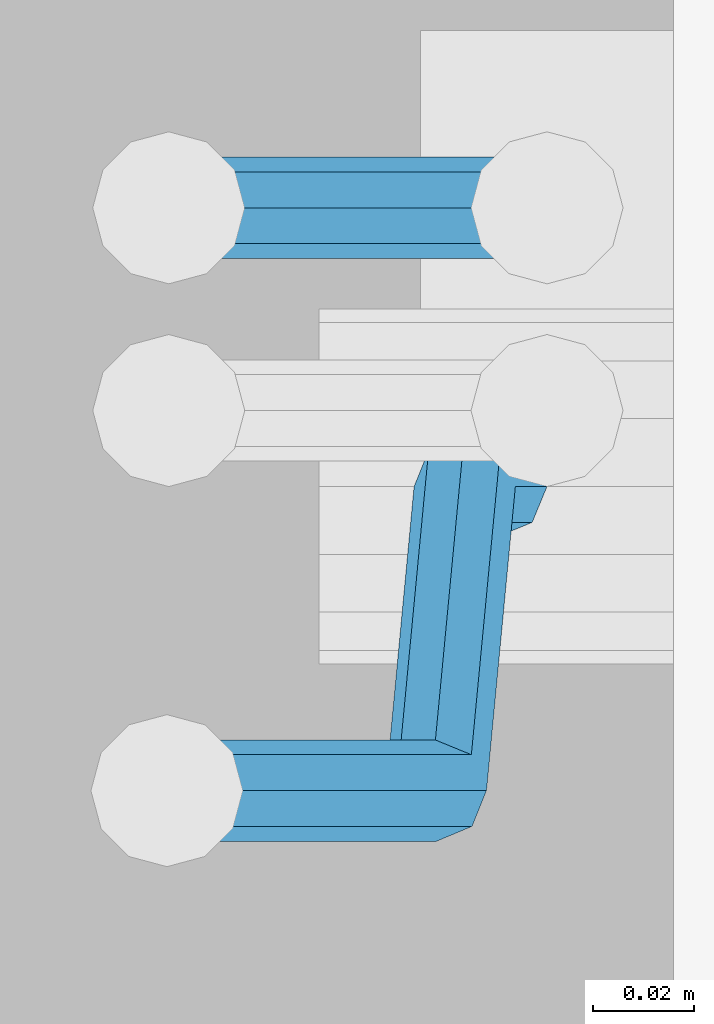
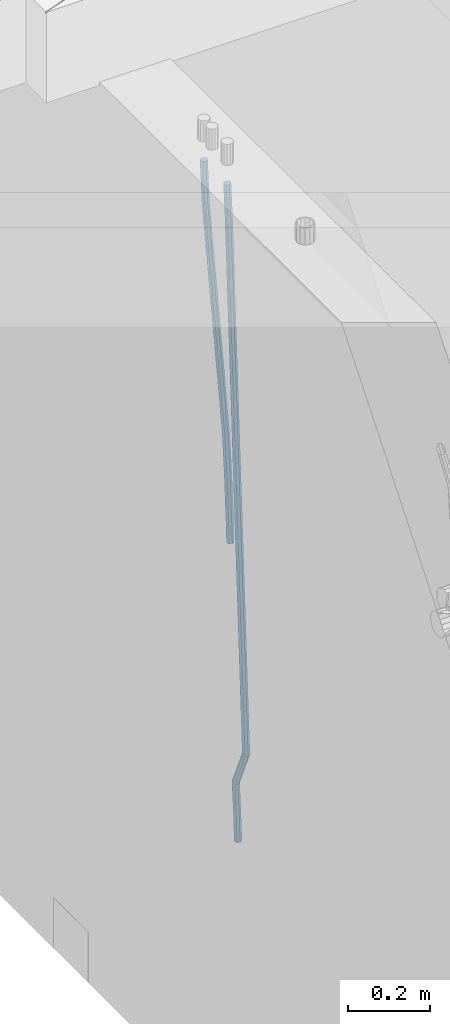
# One storey, part 107 of 350: 2 beams, 1 element without a shape of its own.
"""IFC2X3 building model written with IfcOpenShell, lengths in millimetres."""

from ifc_helpers import new_model, si_unit, frame, origin_with_axes, place, context, subcontext, project, spatial, faceted_brep, material, type_object, element, aggregate, save


model = new_model("IFC2X3")

# Units and contexts
model_context = context("Model", 3, precision=1e-05, world=origin_with_axes())
body_context = subcontext(model_context, "Body", "Model", "MODEL_VIEW")
ifc_project = project(units=[si_unit("LENGTHUNIT", "METRE", prefix="MILLI"), si_unit("AREAUNIT", "SQUARE_METRE"), si_unit("VOLUMEUNIT", "CUBIC_METRE"), si_unit("MASSUNIT", "GRAM", prefix="KILO"), si_unit("TIMEUNIT", "SECOND"), si_unit("PLANEANGLEUNIT", "RADIAN"), si_unit("SOLIDANGLEUNIT", "STERADIAN"), si_unit("THERMODYNAMICTEMPERATUREUNIT", "DEGREE_CELSIUS"), si_unit("LUMINOUSINTENSITYUNIT", "LUMEN")], contexts=[model_context])

# Site, building, storey
site_placement = place(None, origin_with_axes())
site = spatial("IfcSite", under=ifc_project, at=site_placement, CompositionType="ELEMENT")
building_placement = place(site_placement, origin_with_axes())
building = spatial("IfcBuilding", under=site, at=building_placement, CompositionType="ELEMENT")
storey_placement = place(building_placement, origin_with_axes())
storey = spatial("IfcBuildingStorey", under=building, at=storey_placement, Name="2", CompositionType="ELEMENT", Elevation=0.0)

# Assembly, beams
assembly_placement = place(storey_placement, origin_with_axes())
assembly = element("IfcElementAssembly", 1, at=assembly_placement, inside=storey, AssemblyPlace="NOTDEFINED", PredefinedType="REINFORCEMENT_UNIT")
ifc_material = material()
beam_type = type_object("IfcBeamType", Name="D20", PredefinedType="NOTDEFINED")
beam_1_placement = place(assembly_placement, frame((21885.0000022791, 14045.0000000039, 86242.5), z_axis=(-0.999642804636942, -0.000205726999925762, -0.0267249099902983), x_axis=(-0.0267249099948371, 4.30000201934385e-08, 0.999642825806181)))
beam_1 = element("IfcBeam", 2, at=beam_1_placement, type_object=beam_type, material=ifc_material, Name="JM20", ObjectType="D20", context=body_context, shape_type="Brep", body=[
    faceted_brep([(0.0, -10.0, 0.0), (-4.19531716033816e-08, -7.07106781186667, -7.07106781187031), (60.4619050310575, -7.0710677960451, -7.07106780569666), (60.4619050351321, -9.99999998418207, 6.16637407802045e-09), (0.0, 0.0, -10.0), (60.461905027827, 1.58197508426383e-08, -9.99999999383363), (4.196772351861e-08, 7.07106781186303, -7.07106781186667), (60.4619050273614, 7.07106782768642, -7.07106780570393), (0.0, 10.0, 0.0), (60.4619050298934, 10.0000000158198, 6.16273609921336e-09), (4.196772351861e-08, 7.07106781185939, 7.07106781185939), (60.4619050339825, 7.07106782768642, 7.07106781802941), (0.0, 0.0, 10.0), (60.4619050371984, 1.58197508426383e-08, 10.0000000061664), (-4.19531716033816e-08, -7.07106781187031, 7.07106781185939), (60.4619050376641, -7.07106779604692, 7.07106781802941), (61.0129192658205, -7.0710677959014, -7.07106780564573), (60.991799419251, -9.99999998403655, 6.21366780251265e-09), (61.0216667879577, 1.5965269994922e-08, -9.99999999377542), (61.0129104985535, 7.07106782783012, -7.07106780564573), (60.9917724058905, 10.0000000159635, 6.21366780251265e-09), (60.9706525593356, 7.07106782781921, 7.07106781808398), (60.9619050371984, 1.59507180796936e-08, 10.0000000062173), (60.9706613266026, -7.07106779591231, 7.07106781808398), (61.5639236610441, -7.07106711285996, -7.06777487693398), (61.5216697265278, -9.99999932719038, 0.00316667643710389), (61.5814185523195, 7.09851519786753e-07, -9.99665478878524), (61.5639061303518, 7.07106851086064, -7.0677749293136), (61.5216449344152, 10.0000006727951, 0.00316660236785538), (61.4793909998989, 7.07106845846647, 7.07410815574622), (61.4618961086089, 6.35754986433312e-07, 10.0029880675975), (61.4794085305912, -7.07106716525595, 7.07410820811856), (201.449097232471, -7.07089370716676, -6.23178897958132), (201.406843297969, -9.99982592149536, 0.839152573797037), (201.466592123761, 0.000174115546542453, -9.16066889142894), (201.449079701793, 7.07124191655566, -6.23178903195003), (201.406818505828, 10.0001740784883, 0.839152499731426), (201.364564571326, 7.07124186416149, 7.91009405310251), (201.347069680036, 0.000174041450009099, 10.8389739649538), (201.364582102004, -7.07089375956093, 7.91009410547849), (202.064908398519, -7.07089294378966, -6.22810875073264), (201.974688451053, -9.99982521757738, 0.842546146737732), (202.102263221896, 0.000174903541847016, -9.1568699750751), (202.064870972245, 7.07124267990912, -6.22810892200869), (201.974635522289, 10.0001747823735, 0.842545904521103), (201.884415574823, 7.07124250858396, 7.91320080199148), (201.847060751446, 0.000174661254277453, 10.8419620263303), (201.884453001097, -7.07089311511299, 7.91320097326388), (202.680612950673, -7.07089044784516, -6.21607376842803), (202.542435294468, -9.99982291604465, 0.853643714868667), (202.737824267795, 0.000177479978447082, -9.144446864153), (202.680555632222, 7.07124517576995, -6.21607432852397), (202.542354233941, 10.0001770837898, 0.853642922764266), (202.404176577751, 7.07124461559215, 7.92336040606824), (202.3469652606, 0.000176687766725081, 10.8517335017932), (202.404233896188, -7.07089100802477, 7.92336096616782), (324.430210789345, -7.07039689928752, -3.83627285367038), (324.292033133141, -9.99932936748701, 3.23344462962268), (324.487422106482, 0.00067102853608958, -6.76464594940262), (324.430153470879, 7.07173872432759, -3.83627341376996), (324.291952072614, 10.0006706323456, 3.23344383752556), (324.153774416409, 7.07173816414797, 10.3031613208259), (324.096563099272, 0.00067023632254859, 13.2315344165509), (324.15383173486, -7.07039745946895, 10.3031618809218), (325.221961482646, -7.07039368968981, -3.82079675306886), (324.96291781617, -9.99932664785774, 3.24655820051703), (325.329216503131, 0.000674441002047388, -6.74819166034285), (325.221854341275, 7.07174193372339, -3.82079828704082), (324.962766295401, 10.000673351693, 3.24655603115389), (324.703722628925, 7.07174039352867, 10.3139109847434), (324.596467608426, 0.000672262834996218, 13.2413058920174), (324.703829770282, -7.07039522988453, 10.3139125187117), (326.012720342245, -7.07038490384184, -3.77826328435913), (325.632962075513, -9.99931920322524, 3.28259865228756), (326.169956375859, 0.000683782172927749, -6.70296980459898), (326.012563440352, 7.0717507190202, -3.77826749485394), (325.632740182729, 10.0006807955415, 3.28259269774208), (325.252981915997, 7.07174649615627, 10.3434546343924), (325.095745882398, 0.000677810141496593, 13.2681611546395), (325.253138817905, -7.07038912670396, 10.3434588448908), (1042.67017203137, -7.06242237136939, 34.7694266079816), (1042.29041376463, -9.99135667075461, 41.8302885446246), (1042.82740806497, 0.00864631464173726, 31.8447200877308), (1042.67001512948, 7.07971325149083, 34.7694223974795), (1042.29019187186, 10.0086433280121, 41.8302825900792), (1041.91043360511, 7.07970902862871, 48.8911445267258), (1041.7531975715, 0.00864034261394409, 51.8158510469766), (1041.91059050702, -7.06242659423333, 48.8911487372243), (1043.18248629157, -7.06241667922404, 34.7969830523944), (1042.9263787064, -9.9913496047684, 41.8644959324083), (1043.32668633896, 0.00865186195005663, 31.8715753503566), (1043.27450841649, 7.07971996780543, 34.8019369826798), (1043.05651764349, 10.0086518423905, 41.8715018478069), (1042.80041005831, 7.07971891684792, 48.9390147278209), (1042.65621001093, 0.00865037567200488, 51.8644224298623), (1042.7083879334, -7.06241773018337, 48.9340607975319), (1043.69545208351, -7.06910585812511, 34.8038102054488), (1043.56315243173, -9.99965326445817, 41.8729708672981), (1043.82659956625, 0.00213289116436499, 31.8782287845097), (1043.8797704632, 7.07182722685502, 34.8099925230272), (1043.82381798407, 9.9986460889304, 41.8817139846578), (1043.69151833229, 7.06809868259734, 48.9508746465071), (1043.56037084955, -0.00314006669395894, 51.8764560674499), (1043.5071999526, -7.07283440238098, 48.9446923289324), (1065.39976930973, -7.35213459635997, 35.0926768279423), (1065.26746965795, -10.2826820026949, 42.1618374897844), (1065.53091679249, -0.280895847070497, 32.1670954069959), (1065.58408768944, 6.78879848861834, 35.0988591455134), (1065.52813521029, 9.71561735069372, 42.1705806071441), (1065.39583555849, 6.7850699443643, 49.2397412689934), (1065.26468807577, -0.286168804927001, 52.1653226899398), (1065.21151717882, -7.35586314061948, 49.2335589514187), (1066.03519060113, -7.36042062003617, 35.101133763048), (1065.92755813799, -10.2912896915532, 42.1706227248978), (1066.10920635443, -0.288436861303126, 32.1747919657428), (1066.10624797344, 6.78198941166011, 35.1058086697049), (1066.0280484376, 9.70909837990621, 42.1772340413045), (1065.92041597444, 6.77822930838374, 49.2467230031543), (1065.84640022113, -0.293754450345659, 52.1730648004559), (1065.84935860215, -7.36418072330707, 49.2420480964902), (1066.67066571087, -7.35854502446455, 35.109395924319), (1066.58770237108, -10.2893211465962, 42.1792129069727), (1066.68754515388, -0.286739672632393, 32.1822936177959), (1066.62845295128, 6.78352724425349, 35.1125628201116), (1066.52800451398, 9.71058925588841, 42.1836915739514), (1066.44504117421, 6.77981313375676, 49.2535085566051), (1066.42816173119, -0.291992218073574, 52.1806108631245), (1066.48725393378, -7.3622591349631, 49.250341660816), (1166.69145182187, -7.06028288386733, 36.4067701631357), (1166.60848848207, -9.99105900599898, 43.4765871457894), (1166.70833126486, 0.0115224679630046, 33.4796678566127), (1166.6492390623, 7.08178938485253, 36.4099370589247), (1166.54879062499, 10.0088513964856, 43.4810658127681), (1166.4658272852, 7.07807527435216, 50.5508827954218), (1166.44894784222, 0.0062699225218239, 53.4779851019448), (1166.50804004478, -7.0639969943677, 50.5477158996291)], [[[0, 1, 2, 3]], [[1, 4, 5, 2]], [[4, 6, 7, 5]], [[6, 8, 9, 7]], [[8, 10, 11, 9]], [[10, 12, 13, 11]], [[12, 14, 15, 13]], [[14, 0, 3, 15]], [[14, 12, 10, 8, 6, 4, 1, 0]], [[3, 2, 16, 17]], [[2, 5, 18, 16]], [[5, 7, 19, 18]], [[7, 9, 20, 19]], [[9, 11, 21, 20]], [[11, 13, 22, 21]], [[13, 15, 23, 22]], [[15, 3, 17, 23]], [[17, 16, 24, 25]], [[16, 18, 26, 24]], [[18, 19, 27, 26]], [[19, 20, 28, 27]], [[20, 21, 29, 28]], [[21, 22, 30, 29]], [[22, 23, 31, 30]], [[23, 17, 25, 31]], [[25, 24, 32, 33]], [[24, 26, 34, 32]], [[26, 27, 35, 34]], [[27, 28, 36, 35]], [[28, 29, 37, 36]], [[29, 30, 38, 37]], [[30, 31, 39, 38]], [[31, 25, 33, 39]], [[33, 32, 40, 41]], [[32, 34, 42, 40]], [[34, 35, 43, 42]], [[35, 36, 44, 43]], [[36, 37, 45, 44]], [[37, 38, 46, 45]], [[38, 39, 47, 46]], [[39, 33, 41, 47]], [[41, 40, 48, 49]], [[40, 42, 50, 48]], [[42, 43, 51, 50]], [[43, 44, 52, 51]], [[44, 45, 53, 52]], [[45, 46, 54, 53]], [[46, 47, 55, 54]], [[47, 41, 49, 55]], [[49, 48, 56, 57]], [[48, 50, 58, 56]], [[50, 51, 59, 58]], [[51, 52, 60, 59]], [[52, 53, 61, 60]], [[53, 54, 62, 61]], [[54, 55, 63, 62]], [[55, 49, 57, 63]], [[57, 56, 64, 65]], [[56, 58, 66, 64]], [[58, 59, 67, 66]], [[59, 60, 68, 67]], [[60, 61, 69, 68]], [[61, 62, 70, 69]], [[62, 63, 71, 70]], [[63, 57, 65, 71]], [[65, 64, 72, 73]], [[64, 66, 74, 72]], [[66, 67, 75, 74]], [[67, 68, 76, 75]], [[68, 69, 77, 76]], [[69, 70, 78, 77]], [[70, 71, 79, 78]], [[71, 65, 73, 79]], [[73, 72, 80, 81]], [[72, 74, 82, 80]], [[74, 75, 83, 82]], [[75, 76, 84, 83]], [[76, 77, 85, 84]], [[77, 78, 86, 85]], [[78, 79, 87, 86]], [[79, 73, 81, 87]], [[81, 80, 88, 89]], [[80, 82, 90, 88]], [[82, 83, 91, 90]], [[83, 84, 92, 91]], [[84, 85, 93, 92]], [[85, 86, 94, 93]], [[86, 87, 95, 94]], [[87, 81, 89, 95]], [[89, 88, 96, 97]], [[88, 90, 98, 96]], [[90, 91, 99, 98]], [[91, 92, 100, 99]], [[92, 93, 101, 100]], [[93, 94, 102, 101]], [[94, 95, 103, 102]], [[95, 89, 97, 103]], [[97, 96, 104, 105]], [[96, 98, 106, 104]], [[98, 99, 107, 106]], [[99, 100, 108, 107]], [[100, 101, 109, 108]], [[101, 102, 110, 109]], [[102, 103, 111, 110]], [[103, 97, 105, 111]], [[105, 104, 112, 113]], [[104, 106, 114, 112]], [[106, 107, 115, 114]], [[107, 108, 116, 115]], [[108, 109, 117, 116]], [[109, 110, 118, 117]], [[110, 111, 119, 118]], [[111, 105, 113, 119]], [[113, 112, 120, 121]], [[112, 114, 122, 120]], [[114, 115, 123, 122]], [[115, 116, 124, 123]], [[116, 117, 125, 124]], [[117, 118, 126, 125]], [[118, 119, 127, 126]], [[119, 113, 121, 127]], [[121, 120, 128, 129]], [[120, 122, 130, 128]], [[122, 123, 131, 130]], [[123, 124, 132, 131]], [[124, 125, 133, 132]], [[125, 126, 134, 133]], [[126, 127, 135, 134]], [[127, 121, 129, 135]], [[130, 131, 132, 133, 134, 135, 129, 128]]]),
])
beam_2_placement = place(assembly_placement, frame((21875.0000022791, 13990.0000000039, 85390.0), z_axis=(-0.999642804636942, -0.000205726999925762, -0.0267249099902983), x_axis=(-0.0267249099948371, 4.30000201934385e-08, 0.999642825806181)))
beam_2 = element("IfcBeam", 3, at=beam_2_placement, type_object=beam_type, material=ifc_material, Name="JM20", ObjectType="D20", context=body_context, shape_type="Brep", body=[
    faceted_brep([(0.0, -10.0, 0.0), (-4.19531716033816e-08, -7.07106781186667, -7.07106781187031), (60.4266690400545, -7.0710677960451, -7.07106780570757), (60.4266690441291, -9.99999998418934, 6.15546014159918e-09), (0.0, 0.0, -10.0), (60.426669036824, 1.58106558956206e-08, -9.99999999384454), (4.196772351861e-08, 7.07106781186303, -7.07106781186667), (60.4266690363438, 7.07106782768096, -7.07106780570757), (0.0, 10.0, 0.0), (60.4266690388904, 10.0000000158179, 6.15182216279209e-09), (4.196772351861e-08, 7.07106781185939, 7.07106781185939), (60.4266690429649, 7.07106782768096, 7.07106781802577), (0.0, 0.0, 10.0), (60.4266690461809, 1.58179318532348e-08, 10.0000000061555), (-4.19531716033816e-08, -7.07106781187031, 7.07106781185939), (60.4266690466611, -7.07106779605238, 7.07106781802213), (61.0378400410118, -7.07106779588503, -7.07106780564936), (60.991799419251, -9.99999998403655, 6.21366780251265e-09), (61.0569027789461, 1.5985278878361e-08, -9.99999999378269), (61.0378209396877, 7.07106782784831, -7.07106780564936), (60.9917724058905, 10.0000000159635, 6.21366780251265e-09), (60.9457317841297, 7.07106782781193, 7.0710678180767), (60.9266690461809, 1.59488990902901e-08, 10.0000000062028), (60.9457508854539, -7.07106779591413, 7.0710678180767), (61.6489592143771, -7.07106614513759, -7.06310863441468), (61.5568818710308, -9.9999984576425, 0.00735959856683621), (61.6870830769039, 1.71821739058942e-06, -9.99179257185824), (61.6489210170112, 7.07106947854481, -7.06310888312146), (61.556827851804, 10.0000015422847, 0.00735924683976918), (61.4647505084577, 7.07106922979438, 7.07782747982128), (61.4266266459163, 1.36643211590126e-06, 10.0065114172685), (61.464788705809, -7.07106639389531, 7.07782772852806), (174.267124625709, -7.07076194157162, -5.59637791929345), (174.175047282362, -9.99969425407471, 1.47409031368807), (174.305248488221, 0.000305921783365193, -8.52506185673701), (174.267086428299, 7.07137368210897, -5.59637816800023), (174.174993263092, 10.0003057458543, 1.47408996196464), (174.082915919746, 7.07137343335489, 8.54455819494251), (174.044792057219, 0.000305569994452526, 11.4732421323897), (174.082954117155, -7.07076219032751, 8.54455844364929), (175.465419836837, -7.07075870474546, -5.58077141047033), (174.675004882112, -9.99969290359149, 1.48060172474288), (177.145159069318, 0.000313592932798201, -8.48807506990488), (178.730254118374, 7.07138573798329, -5.53825019979558), (179.292177801923, 10.0003195683566, 1.54073579756368), (178.501762847169, 7.07138536951243, 8.60210893278781), (176.822023614717, 0.000313071834170842, 11.5094125922224), (175.236928565646, -7.07075907321996, 8.55958772211307), (176.542315058832, -7.59611953619242, -5.55961357871638), (175.124311484789, -10.2188860855731, 1.48942928132965), (179.697356647346, -1.24477006445522, -8.43793187504707), (182.741255677611, 5.11462794847284, -5.45944578648778), (183.890937380216, 7.7568253951431, 1.63108793160791), (182.472933806173, 5.13405884576423, 8.68013079165394), (179.317892217674, -1.21729062597296, 11.558449087981), (176.273993187395, -7.57668863890103, 8.57996299942533), (294.482485661632, -65.132957683747, -3.24243523495898), (293.06448208759, -67.7557242331259, 3.80660762509069), (297.637527250132, -58.781608212008, -6.12075353128603), (300.681426280426, -52.4222101990799, -3.14226744273765), (301.831107983016, -49.7800127524115, 3.94826627536895), (300.413104408974, -52.4027793017904, 10.9973091354113), (297.258062820474, -58.7541287735276, 13.875627431742), (294.21416379021, -65.1135267864556, 10.8971413431864), (298.421583736403, -67.0546375254562, -3.16504351417098), (297.663123076651, -69.9991605528539, 3.89695742919866), (300.088121800494, -59.9771250684644, -6.07260653783669), (301.686501873191, -52.9125339913189, -3.12252065599023), (302.280414585708, -49.9992059343895, 3.95709383194844), (301.521953925956, -52.9437289617854, 11.0190947753181), (299.85541586185, -60.0212414187808, 13.9266577989838), (298.257035789167, -67.0858324959263, 10.9765719171337), (302.80508749804, -67.0546344167942, -3.14983474865585), (302.780578821912, -69.9991569236881, 3.9147126744756), (302.815190338995, -59.9771231344985, -6.06314484960967), (302.804969237535, -52.9125331981322, -3.11864008263728), (302.780411576299, -49.9992055798066, 3.95882859423), (302.755902900171, -52.9437280867041, 11.0233760173651), (302.745800059231, -60.0212393689962, 13.9366861183116), (302.756021160661, -67.0858293053625, 10.9921813513429), (1894.37301142162, -67.0535057190937, 2.37218249376019), (1894.34850274549, -69.9980282259894, 9.43672991689164), (1894.38311426257, -59.9759944368016, -0.541127607189992), (1894.37289316114, -52.9114045004335, 2.40337715977876), (1894.3483354999, -49.9980768821079, 9.48084583664968), (1894.32382682376, -52.9425993890054, 16.5453932597811), (1894.31372398282, -60.0201106712957, 19.4587033607313), (1894.32394508425, -67.0847006076656, 16.5141985937626), (1894.94277889279, -67.0535053150288, 2.37415932789372), (1894.86432075454, -69.9980278601852, 9.43851957091829), (1895.0133567763, -59.9759939898522, -0.538940952144912), (1895.03471083808, -52.9114040310888, 2.40567336628737), (1894.99433215841, -49.9980764239845, 9.48308715141684), (1894.91587402015, -52.9425989691426, 16.5474473944378), (1894.84529613666, -60.0201102943192, 19.4605476744728), (1894.82394207484, -67.0847002530791, 16.5159333560405), (1895.51245091228, -67.0609340437168, 2.38174109977626), (1895.38005234992, -70.0047531862801, 9.44538344903776), (1895.6434937071, -59.9842112027982, -0.530554452016077), (1895.69641764244, -52.9200329265786, 2.41448003025289), (1895.64022059477, -50.006499042247, 9.49168328852465), (1895.50782203241, -52.9503181848104, 16.5553256377789), (1895.37677923759, -60.027041025729, 19.4676211895749), (1895.32385530225, -67.0912193019485, 16.5225867073132), (1917.33799758967, -67.3455470476256, 2.67221756784056), (1917.20559902734, -70.2893661901871, 9.73585991709842), (1917.46904038449, -60.268824206707, -0.240077983955416), (1917.52196431985, -53.2046459304893, 2.70495649831355), (1917.46576727217, -50.2911120461595, 9.78215975658895), (1917.33336870981, -53.234931188721, 16.8458021058395), (1917.20232591499, -60.3116540296396, 19.7580976576355), (1917.14940197964, -67.3758323058573, 16.8130631753702), (1917.97330892029, -67.3538317366147, 2.68067293412241), (1917.86568243519, -70.2979739160019, 9.74464497525332), (1918.04717802502, -60.2763633301474, -0.232383543014294), (1918.04401822969, -53.2114537018442, 2.71190452019073), (1917.96568049955, -50.2976310950253, 9.78881310785437), (1917.85805401445, -53.2417732744125, 16.8527851489889), (1917.7841849097, -60.3192416808779, 19.765841626122), (1917.78734470502, -67.3841513091829, 16.821553562917), (1918.60867404319, -67.35195819615, 2.68893534464951), (1918.52582156437, -70.2960054380383, 9.75323750879761), (1918.62536489758, -60.2746689828309, -0.224883896320534), (1918.56611685139, -53.2099178344106, 2.71865557893034), (1918.46563660656, -50.2961401588382, 9.79526826718939), (1918.38278412774, -53.2401874007264, 16.8595704313339), (1918.36609327333, -60.3174766140455, 19.7733896723039), (1918.42534131953, -67.3822277624658, 16.829850197053), (2018.6294627928, -67.0536953284463, 3.98631340757856), (2018.54661031398, -69.9977425703346, 11.0506155717267), (2018.64615364719, -59.9764061151272, 1.07249416660852), (2018.586905601, -52.9116549667069, 4.01603364186303), (2018.48642535615, -49.9978772911327, 11.0926463301184), (2018.40357287733, -52.9419245330228, 18.1569484942629), (2018.38688202295, -60.01921374634, 21.0707677352366), (2018.44613006913, -67.0839648947622, 18.1272282599821)], [[[0, 1, 2, 3]], [[1, 4, 5, 2]], [[4, 6, 7, 5]], [[6, 8, 9, 7]], [[8, 10, 11, 9]], [[10, 12, 13, 11]], [[12, 14, 15, 13]], [[14, 0, 3, 15]], [[14, 12, 10, 8, 6, 4, 1, 0]], [[3, 2, 16, 17]], [[2, 5, 18, 16]], [[5, 7, 19, 18]], [[7, 9, 20, 19]], [[9, 11, 21, 20]], [[11, 13, 22, 21]], [[13, 15, 23, 22]], [[15, 3, 17, 23]], [[17, 16, 24, 25]], [[16, 18, 26, 24]], [[18, 19, 27, 26]], [[19, 20, 28, 27]], [[20, 21, 29, 28]], [[21, 22, 30, 29]], [[22, 23, 31, 30]], [[23, 17, 25, 31]], [[25, 24, 32, 33]], [[24, 26, 34, 32]], [[26, 27, 35, 34]], [[27, 28, 36, 35]], [[28, 29, 37, 36]], [[29, 30, 38, 37]], [[30, 31, 39, 38]], [[31, 25, 33, 39]], [[33, 32, 40, 41]], [[32, 34, 42, 40]], [[34, 35, 43, 42]], [[35, 36, 44, 43]], [[36, 37, 45, 44]], [[37, 38, 46, 45]], [[38, 39, 47, 46]], [[39, 33, 41, 47]], [[41, 40, 48, 49]], [[40, 42, 50, 48]], [[42, 43, 51, 50]], [[43, 44, 52, 51]], [[44, 45, 53, 52]], [[45, 46, 54, 53]], [[46, 47, 55, 54]], [[47, 41, 49, 55]], [[49, 48, 56, 57]], [[48, 50, 58, 56]], [[50, 51, 59, 58]], [[51, 52, 60, 59]], [[52, 53, 61, 60]], [[53, 54, 62, 61]], [[54, 55, 63, 62]], [[55, 49, 57, 63]], [[57, 56, 64, 65]], [[56, 58, 66, 64]], [[58, 59, 67, 66]], [[59, 60, 68, 67]], [[60, 61, 69, 68]], [[61, 62, 70, 69]], [[62, 63, 71, 70]], [[63, 57, 65, 71]], [[65, 64, 72, 73]], [[64, 66, 74, 72]], [[66, 67, 75, 74]], [[67, 68, 76, 75]], [[68, 69, 77, 76]], [[69, 70, 78, 77]], [[70, 71, 79, 78]], [[71, 65, 73, 79]], [[73, 72, 80, 81]], [[72, 74, 82, 80]], [[74, 75, 83, 82]], [[75, 76, 84, 83]], [[76, 77, 85, 84]], [[77, 78, 86, 85]], [[78, 79, 87, 86]], [[79, 73, 81, 87]], [[81, 80, 88, 89]], [[80, 82, 90, 88]], [[82, 83, 91, 90]], [[83, 84, 92, 91]], [[84, 85, 93, 92]], [[85, 86, 94, 93]], [[86, 87, 95, 94]], [[87, 81, 89, 95]], [[89, 88, 96, 97]], [[88, 90, 98, 96]], [[90, 91, 99, 98]], [[91, 92, 100, 99]], [[92, 93, 101, 100]], [[93, 94, 102, 101]], [[94, 95, 103, 102]], [[95, 89, 97, 103]], [[97, 96, 104, 105]], [[96, 98, 106, 104]], [[98, 99, 107, 106]], [[99, 100, 108, 107]], [[100, 101, 109, 108]], [[101, 102, 110, 109]], [[102, 103, 111, 110]], [[103, 97, 105, 111]], [[105, 104, 112, 113]], [[104, 106, 114, 112]], [[106, 107, 115, 114]], [[107, 108, 116, 115]], [[108, 109, 117, 116]], [[109, 110, 118, 117]], [[110, 111, 119, 118]], [[111, 105, 113, 119]], [[113, 112, 120, 121]], [[112, 114, 122, 120]], [[114, 115, 123, 122]], [[115, 116, 124, 123]], [[116, 117, 125, 124]], [[117, 118, 126, 125]], [[118, 119, 127, 126]], [[119, 113, 121, 127]], [[121, 120, 128, 129]], [[120, 122, 130, 128]], [[122, 123, 131, 130]], [[123, 124, 132, 131]], [[124, 125, 133, 132]], [[125, 126, 134, 133]], [[126, 127, 135, 134]], [[127, 121, 129, 135]], [[130, 131, 132, 133, 134, 135, 129, 128]]]),
])
aggregate(assembly, [beam_1, beam_2])

save(model, "model.ifc")
